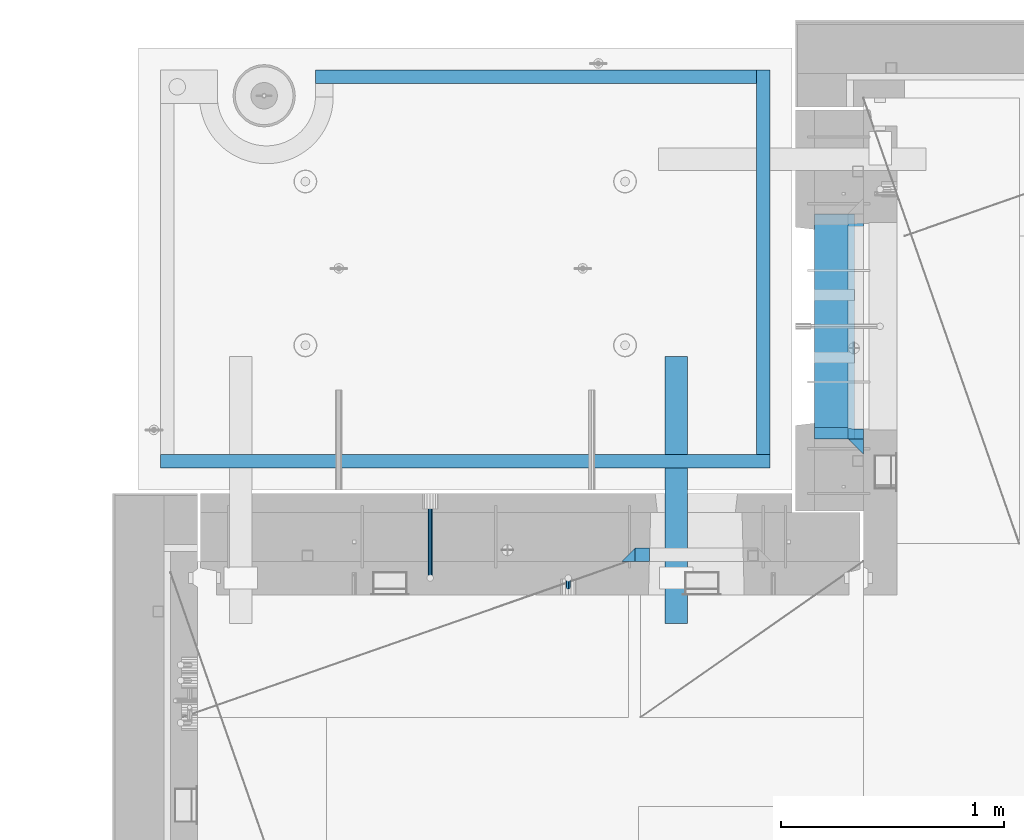
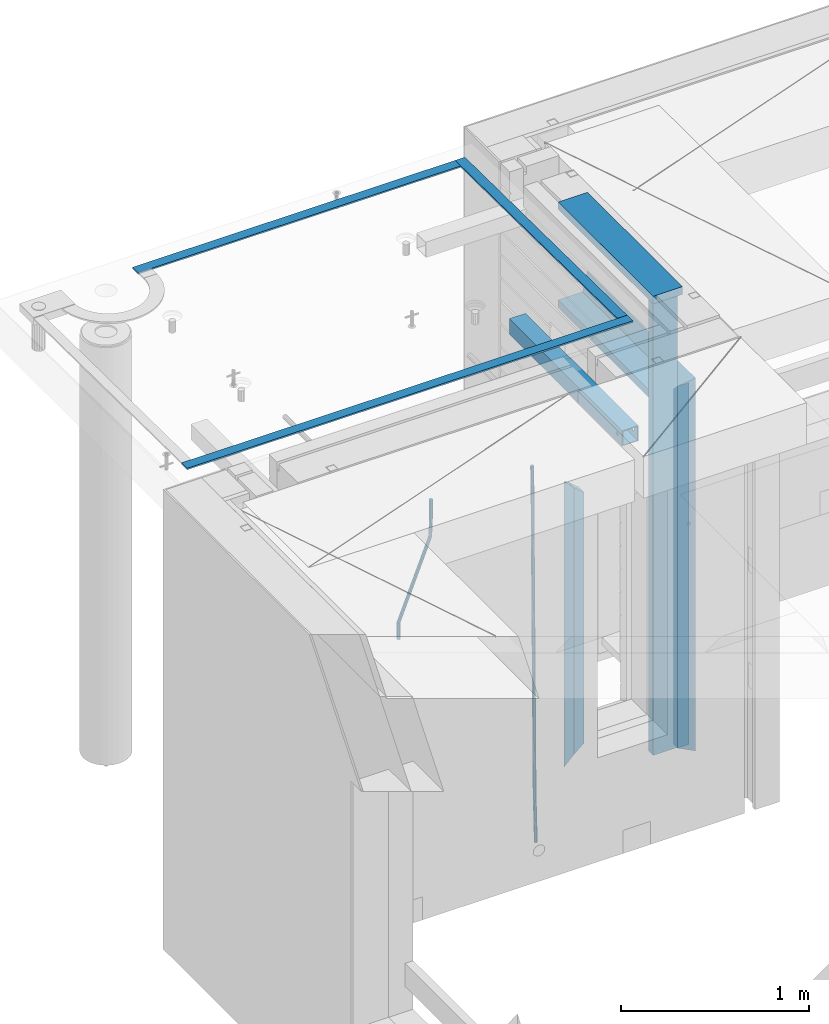
# One storey, part 116 of 350: 14 beams, 4 elements without a shape of their own.
"""IFC2X3 building model written with IfcOpenShell, lengths in millimetres."""

from ifc_helpers import new_model, si_unit, frame, origin_with_axes, place, context, subcontext, project, spatial, faceted_brep, material, type_object, element, aggregate, save


model = new_model("IFC2X3")

# Units and contexts
model_context = context("Model", 3, precision=1e-05, world=origin_with_axes())
body_context = subcontext(model_context, "Body", "Model", "MODEL_VIEW")
ifc_project = project(units=[si_unit("LENGTHUNIT", "METRE", prefix="MILLI"), si_unit("AREAUNIT", "SQUARE_METRE"), si_unit("VOLUMEUNIT", "CUBIC_METRE"), si_unit("MASSUNIT", "GRAM", prefix="KILO"), si_unit("TIMEUNIT", "SECOND"), si_unit("PLANEANGLEUNIT", "RADIAN"), si_unit("SOLIDANGLEUNIT", "STERADIAN"), si_unit("THERMODYNAMICTEMPERATUREUNIT", "DEGREE_CELSIUS"), si_unit("LUMINOUSINTENSITYUNIT", "LUMEN")], contexts=[model_context])

# Site, building, storey
site_placement = place(None, origin_with_axes())
site = spatial("IfcSite", under=ifc_project, at=site_placement, CompositionType="ELEMENT")
building_placement = place(site_placement, origin_with_axes())
building = spatial("IfcBuilding", under=site, at=building_placement, CompositionType="ELEMENT")
storey_placement = place(building_placement, origin_with_axes())
storey = spatial("IfcBuildingStorey", under=building, at=storey_placement, Name="2", CompositionType="ELEMENT", Elevation=0.0)

# Assembly, beams
assembly_1_placement = place(storey_placement, origin_with_axes())
assembly_1 = element("IfcElementAssembly", 1, at=assembly_1_placement, inside=storey, AssemblyPlace="NOTDEFINED", PredefinedType="REINFORCEMENT_UNIT")
ifc_material_1 = material(Name="CONCRETE/C25/30")
beam_type_1 = type_object("IfcBeamType", PredefinedType="NOTDEFINED")
beam_1_placement = place(assembly_1_placement, frame((10955.0, 22209.9998901814, 87140.0), z_axis=(0.0, 0.0, -1.0), x_axis=(0.0, -1.0, 0.0)))
beam_1 = element("IfcBeam", 2, at=beam_1_placement, type_object=beam_type_1, material=ifc_material_1, Name="SK", context=body_context, shape_type="Brep", body=[
    faceted_brep([(70.0000000000164, -35.0, 35.0), (70.0000000000164, 35.0, 35.0), (0.0, -35.0, -35.0), (1079.99961853027, -35.0, 35.0), (1079.99961853027, 35.0, 35.0), (1149.99961853027, -35.0, -35.0)], [[[0, 1, 2]], [[1, 0, 3, 4]], [[2, 1, 4, 5]], [[0, 2, 5, 3]], [[5, 4, 3]]]),
])
beam_2_placement = place(assembly_1_placement, frame((10955.0, 21095.0002716511, 87175.0), z_axis=(0.0, 1.0, 0.0), x_axis=(0.0, 0.0, -1.0)))
beam_2 = element("IfcBeam", 3, at=beam_2_placement, type_object=beam_type_1, material=ifc_material_1, Name="SK", context=body_context, shape_type="Brep", body=[
    faceted_brep([(2420.0, -35.0, 35.0), (2420.0, -35.0, -35.0), (2420.0, 35.0, 35.0), (70.0000000000164, -35.0, 35.0), (0.0, -35.0, -35.0), (70.0000000000164, 35.0, 35.0)], [[[0, 1, 2]], [[1, 0, 3, 4]], [[2, 1, 4, 5]], [[0, 2, 5, 3]], [[3, 5, 4]]]),
])
beam_type_2 = type_object("IfcBeamType", PredefinedType="NOTDEFINED")
beam_3_placement = place(assembly_1_placement, frame((10955.0, 21155.0002716511, 87105.0), z_axis=(0.0, 1.0, 0.0), x_axis=(0.0, 0.0, -1.0)))
beam_3 = element("IfcBeam", 4, at=beam_3_placement, type_object=beam_type_2, material=ifc_material_1, Name="SK", context=body_context, shape_type="Brep", body=[
    faceted_brep([(2350.0, -35.0, -25.0), (2350.0, 35.0, -25.0), (2350.0, 35.0, 20.6410256410309), (2350.0, -35.0, 18.8461538461561), (43.8461538461561, -35.0, 18.8461538461543), (0.0, -35.0, -25.0), (0.0, 35.0, -25.0), (45.6410256410309, 35.0, 20.6410256410254)], [[[0, 1, 2, 3]], [[0, 3, 4, 5]], [[1, 0, 5, 6]], [[2, 1, 6, 7]], [[3, 2, 7, 4]], [[7, 6, 5, 4]]]),
])
ifc_material_2 = material(Name="TIMBER")
beam_type_3 = type_object("IfcBeamType", Name="50X150", PredefinedType="NOTDEFINED")
beam_4_placement = place(assembly_1_placement, frame((10845.0, 22139.9998901814, 87080.0), z_axis=(0.0, 0.0, -1.0), x_axis=(0.0, -1.0, 0.0)))
beam_4 = element("IfcBeam", 5, at=beam_4_placement, type_object=beam_type_3, material=ifc_material_2, ObjectType="50X150", context=body_context, shape_type="Brep", body=[
    faceted_brep([(0.0, 75.0, -25.0), (1.81898940354586e-12, 75.0, 25.0), (1009.99961853027, 75.0, 25.0), (1009.99961853027, 75.0, -25.0), (1.81898940354586e-12, -75.0000000000009, 25.0), (1009.99961853027, -75.0, 25.0), (0.0, -75.0, -25.0), (1009.99961853027, -75.0, -25.0)], [[[0, 1, 2, 3]], [[1, 4, 5, 2]], [[4, 6, 7, 5]], [[6, 0, 3, 7]], [[5, 7, 3, 2]], [[6, 4, 1, 0]]]),
])
beam_5_placement = place(assembly_1_placement, frame((10845.0, 21155.0002716511, 87690.0), z_axis=(0.0, 1.0, 0.0), x_axis=(0.0, 0.0, -1.0)))
beam_5 = element("IfcBeam", 6, at=beam_5_placement, type_object=beam_type_3, material=ifc_material_2, ObjectType="50X150", context=body_context, shape_type="Brep", body=[
    faceted_brep([(0.0, 75.0, -25.0), (1.81898940354586e-12, 75.0, 25.0), (2930.0, 75.0, 25.0), (2930.0, 75.0, -25.0), (1.81898940354586e-12, -75.0000000000009, 25.0), (2930.0, -75.0, 25.0), (0.0, -75.0, -25.0), (2930.0, -75.0, -25.0)], [[[0, 1, 2, 3]], [[1, 4, 5, 2]], [[4, 6, 7, 5]], [[6, 0, 3, 7]], [[5, 7, 3, 2]], [[6, 4, 1, 0]]]),
])

assembly_2_placement = place(storey_placement, origin_with_axes())
assembly_2 = element("IfcElementAssembly", 7, at=assembly_2_placement, inside=storey, AssemblyPlace="NOTDEFINED", PredefinedType="REINFORCEMENT_UNIT")
ifc_material_3 = material()
beam_type_4 = type_object("IfcBeamType", Name="D20", PredefinedType="NOTDEFINED")
beam_6_placement = place(assembly_2_placement, frame((9665.0017200335, 20464.9951872276, 84990.0), z_axis=(-0.000205762999925498, 0.999642804629538, -0.0267249099901004), x_axis=(4.30000201928125e-08, 0.0267249099948059, 0.999642825806181)))
beam_6 = element("IfcBeam", 8, at=beam_6_placement, type_object=beam_type_4, material=ifc_material_3, Name="JM20", ObjectType="D20", context=body_context, shape_type="Brep", body=[
    faceted_brep([(0.0, -10.0, 0.0), (-4.19531716033816e-08, -7.07106781186667, -7.07106781187031), (60.4266690400545, -7.0710677960451, -7.07106780570757), (60.4266690441291, -9.99999998418934, 6.15546014159918e-09), (0.0, 0.0, -10.0), (60.426669036824, 1.58106558956206e-08, -9.99999999384454), (4.196772351861e-08, 7.07106781186303, -7.07106781186667), (60.4266690363438, 7.07106782768096, -7.07106780570757), (0.0, 10.0, 0.0), (60.4266690388904, 10.0000000158179, 6.15182216279209e-09), (4.196772351861e-08, 7.07106781185939, 7.07106781185939), (60.4266690429649, 7.07106782768096, 7.07106781802577), (0.0, 0.0, 10.0), (60.4266690461809, 1.58179318532348e-08, 10.0000000061555), (-4.19531716033816e-08, -7.07106781187031, 7.07106781185939), (60.4266690466611, -7.07106779605238, 7.07106781802213), (61.0378400410118, -7.07106779588503, -7.07106780564936), (60.991799419251, -9.99999998403655, 6.21366780251265e-09), (61.0569027789461, 1.5985278878361e-08, -9.99999999378269), (61.0378209396877, 7.07106782784831, -7.07106780564936), (60.9917724058905, 10.0000000159635, 6.21366780251265e-09), (60.9457317841297, 7.07106782781193, 7.0710678180767), (60.9266690461809, 1.59488990902901e-08, 10.0000000062028), (60.9457508854539, -7.07106779591413, 7.0710678180767), (61.6489592143771, -7.07106614513759, -7.06310863441468), (61.5568818710308, -9.9999984576425, 0.00735959856683621), (61.6870830769039, 1.71821739058942e-06, -9.99179257185824), (61.6489210170112, 7.07106947854481, -7.06310888312146), (61.556827851804, 10.0000015422847, 0.00735924683976918), (61.4647505084577, 7.07106922979438, 7.07782747982128), (61.4266266459163, 1.36643211590126e-06, 10.0065114172685), (61.464788705809, -7.07106639389531, 7.07782772852806), (176.543135720174, -7.07075579406956, -5.56673531796696), (176.451058376813, -9.99968810657447, 1.50373291501455), (176.581259582701, 0.000312069292704109, -8.49541925541052), (176.543097522794, 7.07137982961285, -5.56673556667374), (176.451004357587, 10.00031189336, 1.50373256329476), (176.35892701424, 7.07137958085514, 8.57420079627263), (176.320803151699, 0.000311717507429421, 11.5028847337162), (176.358965211621, -7.07075604281999, 8.57420104497578), (177.098753836006, -7.07075429323595, -5.55949898843028), (176.98362511232, -9.99968666800123, 1.510669025065), (177.146421932586, 0.000313595905026887, -8.48805862247536), (177.098706077581, 7.07138133041735, -5.55949936166144), (176.983557571715, 10.0003133318824, 1.51066849724157), (176.868428848029, 7.07138095712435, 8.58083651073321), (176.820760751449, 0.000313067976094317, 11.5093961447819), (176.868476606425, -7.07075466652896, 8.58083688396073), (177.654312950661, -7.07075204110879, -5.54863964998367), (177.516135294456, -9.99968450931192, 1.52107783331303), (177.711524267797, 0.000315886711177882, -8.47701274570863), (177.654255632195, 7.07138358250813, -5.54864021007961), (177.516054233929, 10.0003154905207, 1.5210770412159), (177.377876577739, 7.0713830223176, 8.59079452451624), (177.320665260588, 0.000315094497636892, 11.5191676202448), (177.377933896176, -7.07075260129932, 8.59079508461218), (299.436796249574, -7.07025836271714, -3.1681962331204), (299.298618593355, -9.99919083092027, 3.90152125031091), (299.494007566798, 0.000809565110102994, -6.09656932889993), (299.436738931283, 7.07187726089978, -3.16819679320906), (299.298537533061, 10.0008091689197, 3.90152045822106), (299.160359876842, 7.07187670072017, 10.9712379416487), (299.103148559603, 0.000808772889286047, 13.8996110374392), (299.160417195119, -7.07025892290039, 10.9712385017483), (299.98743051647, -7.07025613056248, -3.15743315966392), (299.971788958996, -9.99918809853989, 3.91467979818117), (299.993912075952, 0.000811591617093654, -6.08679785393178), (299.987423933868, 7.07187949325817, -3.1574327280432), (299.971753863239, 10.0008119014747, 3.91467990454839), (299.95611230444, 7.07187992653053, 10.9867922621015), (299.949630744944, 0.000812204350950196, 13.9161569563694), (299.956118887014, -7.07025569729012, 10.9867918304735), (300.538107039494, -7.07025785017686, -3.16575821840888), (300.644985195438, -9.99919020432935, 3.90450175465594), (300.493854948218, 0.000810030429420294, -6.09435592770024), (300.538151196495, 7.071877773491, -3.16575855385963), (300.645047642858, 10.0008097955724, 3.90450128024895), (300.751925798773, 7.07187744142357, 10.9747612533101), (300.796177890064, 0.000809560813650023, 13.9033589625978), (300.751881641787, -7.07025818224065, 10.9747615887682), (2293.36490490142, -7.07648090940347, -33.2930642912361), (2293.47178305736, -10.0054132635523, -26.2228043181785), (2293.32065281013, -0.00541302880083094, -36.2216620005347), (2293.36494905842, 7.06565471425711, -33.2930646266868), (2293.47184550477, 9.99458673634581, -26.2228047925819), (2293.57872366071, 7.06565438219332, -19.1525448195243), (2293.62297575199, -0.00541349841296324, -16.2239471102366), (2293.57867950371, -7.0764812414709, -19.1525444840736), (2294.0658245362, -7.07648309818615, -33.3036607065333), (2294.05312277409, -10.0054150789219, -26.2315929392535), (2294.10928714235, -0.00541549149056664, -36.2335844756526), (2294.15805078732, 7.06565223761572, -33.3050546393533), (2294.18355038921, 9.99458451388637, -26.2335642579346), (2294.17084862708, 7.06565253314329, -19.1614964906439), (2294.12738602093, -0.00541507354500936, -16.2315727215355), (2294.07862237596, -7.07648280265857, -19.1601025578348), (2294.76670261032, -7.08562269121467, -33.294332712383), (2294.63442802057, -10.0129954178956, -26.2238563411993), (2294.89787471293, -0.0156988342423574, -36.2230891548279), (2294.95110548967, 7.05531064255774, -33.2944998654275), (2294.89521307347, 9.98530428734011, -26.2240927312887), (2294.76293848372, 7.0579315606592, -19.1536163601049), (2294.63176638114, -0.0119922963167483, -16.2248599176673), (2294.57853560438, -7.08300177311321, -19.1534492070678), (2316.52657204497, -7.36937582653991, -33.0047303660212), (2316.39429745522, -10.2967485532172, -25.9342539948302), (2316.65774414754, -0.299451969567599, -35.9334868084661), (2316.7109749243, 6.7715575072325, -33.0048975190657), (2316.65508250811, 9.70155115201487, -25.9344903849269), (2316.52280791836, 6.7741784253376, -18.8640140137468), (2316.39163581574, -0.295745431634714, -15.9352575713092), (2316.33840503903, -7.36675490843481, -18.863846860706), (2317.16202064224, -7.37766220584308, -32.9962731735213), (2317.05438744847, -10.3053562613532, -25.9254688497131), (2317.23607125619, -0.306993473008333, -35.925789846493), (2317.23316144495, 6.76474808850253, -32.9979477328052), (2317.15499573652, 9.6950321815566, -25.9278370341635), (2317.04736254275, 6.7673381260538, -18.8570327103698), (2316.97331192881, -0.303330606784584, -15.9275160373909), (2316.97622174003, -7.37507216829545, -18.8553581510787), (2317.79752306276, -7.37578610372293, -32.9880110666527), (2317.71453320107, -10.3033876998124, -25.9168792378296), (2317.81444760226, -0.305295583297266, -35.918287695793), (2317.75539265381, 6.76628640723357, -32.9911928173897), (2317.65495180529, 9.69652304524061, -25.9213789128698), (2317.5719619436, 6.76892144914746, -18.8502470840467), (2317.55503740412, -0.301569071270933, -15.9199704549137), (2317.61409235255, -7.3731510618054, -18.847065333317), (2417.8183084176, -7.07752398473531, -31.6906369377139), (2417.73531855589, -10.0051255808248, -24.6195051088798), (2417.83523295709, -0.007033464313281, -34.6209135668432), (2417.77617800863, 7.06454852621755, -31.6938186884508), (2417.67573716014, 9.99478516423187, -24.6240047839383), (2417.59274729842, 7.06718356813872, -17.5528729551006), (2417.57582275895, -0.00330695228694822, -14.6225963259749), (2417.6348777074, -7.07488894281778, -17.5496912043673)], [[[0, 1, 2, 3]], [[1, 4, 5, 2]], [[4, 6, 7, 5]], [[6, 8, 9, 7]], [[8, 10, 11, 9]], [[10, 12, 13, 11]], [[12, 14, 15, 13]], [[14, 0, 3, 15]], [[14, 12, 10, 8, 6, 4, 1, 0]], [[3, 2, 16, 17]], [[2, 5, 18, 16]], [[5, 7, 19, 18]], [[7, 9, 20, 19]], [[9, 11, 21, 20]], [[11, 13, 22, 21]], [[13, 15, 23, 22]], [[15, 3, 17, 23]], [[17, 16, 24, 25]], [[16, 18, 26, 24]], [[18, 19, 27, 26]], [[19, 20, 28, 27]], [[20, 21, 29, 28]], [[21, 22, 30, 29]], [[22, 23, 31, 30]], [[23, 17, 25, 31]], [[25, 24, 32, 33]], [[24, 26, 34, 32]], [[26, 27, 35, 34]], [[27, 28, 36, 35]], [[28, 29, 37, 36]], [[29, 30, 38, 37]], [[30, 31, 39, 38]], [[31, 25, 33, 39]], [[33, 32, 40, 41]], [[32, 34, 42, 40]], [[34, 35, 43, 42]], [[35, 36, 44, 43]], [[36, 37, 45, 44]], [[37, 38, 46, 45]], [[38, 39, 47, 46]], [[39, 33, 41, 47]], [[41, 40, 48, 49]], [[40, 42, 50, 48]], [[42, 43, 51, 50]], [[43, 44, 52, 51]], [[44, 45, 53, 52]], [[45, 46, 54, 53]], [[46, 47, 55, 54]], [[47, 41, 49, 55]], [[49, 48, 56, 57]], [[48, 50, 58, 56]], [[50, 51, 59, 58]], [[51, 52, 60, 59]], [[52, 53, 61, 60]], [[53, 54, 62, 61]], [[54, 55, 63, 62]], [[55, 49, 57, 63]], [[57, 56, 64, 65]], [[56, 58, 66, 64]], [[58, 59, 67, 66]], [[59, 60, 68, 67]], [[60, 61, 69, 68]], [[61, 62, 70, 69]], [[62, 63, 71, 70]], [[63, 57, 65, 71]], [[65, 64, 72, 73]], [[64, 66, 74, 72]], [[66, 67, 75, 74]], [[67, 68, 76, 75]], [[68, 69, 77, 76]], [[69, 70, 78, 77]], [[70, 71, 79, 78]], [[71, 65, 73, 79]], [[73, 72, 80, 81]], [[72, 74, 82, 80]], [[74, 75, 83, 82]], [[75, 76, 84, 83]], [[76, 77, 85, 84]], [[77, 78, 86, 85]], [[78, 79, 87, 86]], [[79, 73, 81, 87]], [[81, 80, 88, 89]], [[80, 82, 90, 88]], [[82, 83, 91, 90]], [[83, 84, 92, 91]], [[84, 85, 93, 92]], [[85, 86, 94, 93]], [[86, 87, 95, 94]], [[87, 81, 89, 95]], [[89, 88, 96, 97]], [[88, 90, 98, 96]], [[90, 91, 99, 98]], [[91, 92, 100, 99]], [[92, 93, 101, 100]], [[93, 94, 102, 101]], [[94, 95, 103, 102]], [[95, 89, 97, 103]], [[97, 96, 104, 105]], [[96, 98, 106, 104]], [[98, 99, 107, 106]], [[99, 100, 108, 107]], [[100, 101, 109, 108]], [[101, 102, 110, 109]], [[102, 103, 111, 110]], [[103, 97, 105, 111]], [[105, 104, 112, 113]], [[104, 106, 114, 112]], [[106, 107, 115, 114]], [[107, 108, 116, 115]], [[108, 109, 117, 116]], [[109, 110, 118, 117]], [[110, 111, 119, 118]], [[111, 105, 113, 119]], [[113, 112, 120, 121]], [[112, 114, 122, 120]], [[114, 115, 123, 122]], [[115, 116, 124, 123]], [[116, 117, 125, 124]], [[117, 118, 126, 125]], [[118, 119, 127, 126]], [[119, 113, 121, 127]], [[121, 120, 128, 129]], [[120, 122, 130, 128]], [[122, 123, 131, 130]], [[123, 124, 132, 131]], [[124, 125, 133, 132]], [[125, 126, 134, 133]], [[126, 127, 135, 134]], [[127, 121, 129, 135]], [[130, 131, 132, 133, 134, 135, 129, 128]]]),
])
beam_7_placement = place(assembly_2_placement, frame((9044.99633337453, 20504.9951872346, 87407.5), z_axis=(0.000415599999849905, 0.999999913638203, 4.76000000899737e-07), x_axis=(0.0, 0.0, -1.0)))
beam_7 = element("IfcBeam", 9, at=beam_7_placement, type_object=beam_type_4, material=ifc_material_3, Name="JM20", ObjectType="D20", context=body_context, shape_type="Brep", body=[
    faceted_brep([(-0.00060564729210455, -9.99999998165731, 0.0), (-0.000428079845733009, -7.07106779890455, -7.07106781186667), (119.575515501536, -7.07830994756296, -7.07106481604933), (119.575337932896, -10.0072421307195, -3.43332612828817e-06), (0.0, 0.0, -10.0), (119.575943836026, -0.00724214867295814, -9.99999700418266), (0.00042843479604926, 7.07106779888636, -7.07106781186303), (119.57637202373, 7.06382565022977, -7.07106481604933), (0.00060564729210455, 9.99999998166459, 3.63797880709171e-12), (119.576549238118, 9.99275783300072, 2.99581552098971e-06), (0.000428079845733009, 7.07106779890819, 7.07106781186667), (119.576371669405, 7.06382565024978, 7.07107080768037), (0.0, 0.0, 10.0), (119.57594333493, -0.00724214864203532, 10.0000029958155), (-0.000428434810601175, -7.07106779888272, 7.07106781186667), (119.575515147211, -7.07830994754295, 7.07107080768037), (123.00654325854, -7.07836650239551, -6.96786008391246), (122.581588830741, -10.007295666459, 0.0904344953341933), (123.182419066041, -0.00729994480025198, -9.89151006310021), (123.006190977103, 7.06376911688858, -6.96788735351402), (122.581091016109, 9.99270432680532, 0.0903895128230943), (122.156136974867, 7.06377516229986, 7.14867767459873), (121.980261167351, -0.00729139528993983, 10.0723276537792), (122.156489256289, -7.07836045697513, 7.14870494419847), (237.077376207715, -7.07551629289992, -0.0988779924864502), (236.652422053201, -10.0044409119728, 6.95941204931296), (237.253252288647, -0.0044516184279928, -3.02253250974718), (237.077024472936, 7.06661932641327, -0.0989143382521434), (236.651924624995, 9.99555908263574, 6.95936064834314), (236.226970470365, 7.06663446442326, 14.0176506898479), (236.051094389448, -0.0044302100486675, 16.9413052071086), (236.227322205144, -7.07550115488812, 14.0176870356117), (256.715938387759, -7.07353516174771, 4.66794781703175), (253.858321224223, -10.0027051854922, 11.1357628166734), (257.898622435067, -0.00236892073007766, 1.98867362452802), (256.713573090979, 7.0686002544353, 4.66742272414376), (253.85497618909, 9.99729452004976, 11.1350202234971), (250.997359025234, 7.06812449537756, 17.6028352234607), (249.814674977912, -0.00304174564189452, 20.2821094159572), (250.999724322028, -7.07401092080545, 17.6033603163596), (1009.84102825288, -6.93521658215468, 337.477148757798), (1006.98341108896, -9.86438660663771, 343.944963757851), (1011.02371230032, 0.135949658781101, 334.7978745651), (1009.83866295629, 7.20691883402651, 337.476623664521), (1006.98006605446, 10.1356130998429, 343.944221163818), (1004.12244889054, 7.2064430753635, 350.412036163872), (1002.9397648431, 0.135276834424076, 353.091310356571), (1004.12481418712, -6.93569234081951, 350.412561257146), (1010.86335274603, -6.9350288225487, 337.928918327354), (1009.37086865908, -9.86394812736762, 344.999991477531), (1011.48104818776, 0.136033652863262, 334.999973251377), (1010.86211737194, 7.20710680115553, 337.928892551665), (1009.36912157628, 10.1360518725905, 344.9999550252), (1007.87663748935, 7.2071325677698, 352.071028175378), (1007.2589420476, 0.13607009235966, 354.999973251352), (1007.87787286344, -6.93500305593261, 352.071053951067), (1011.98104820926, -6.93502881915083, 337.92891832735), (1011.98104821818, -9.86394811943501, 344.999991477524), (1011.98104818776, 0.136033654382118, 334.999973251375), (1011.98104816627, 7.20710680455704, 337.928892551661), (1011.98104815738, 10.1360518805304, 344.999955025194), (1011.98104816629, 7.20713258024625, 352.071028175369), (1011.98104818778, 0.136070106711486, 354.999973251342), (1011.98104820927, -6.9350030434598, 352.071053951058), (1117.50000002154, -6.93502849844299, 337.928918327156), (1117.50000003044, -9.86394779872717, 344.999991477331), (1117.50000000004, 0.136033975091777, 334.999973251181), (1117.49999997855, 7.20710712526488, 337.928892551467), (1117.49999996964, 10.1360522012383, 344.999955025), (1117.49999997857, 7.20713290095409, 352.071028175174), (1117.50000000006, 0.136070427419327, 354.999973251148), (1117.50000002155, -6.93500272275196, 352.071053950864)], [[[0, 1, 2, 3]], [[1, 4, 5, 2]], [[4, 6, 7, 5]], [[6, 8, 9, 7]], [[8, 10, 11, 9]], [[10, 12, 13, 11]], [[12, 14, 15, 13]], [[14, 0, 3, 15]], [[14, 12, 10, 8, 6, 4, 1, 0]], [[3, 2, 16, 17]], [[2, 5, 18, 16]], [[5, 7, 19, 18]], [[7, 9, 20, 19]], [[9, 11, 21, 20]], [[11, 13, 22, 21]], [[13, 15, 23, 22]], [[15, 3, 17, 23]], [[17, 16, 24, 25]], [[16, 18, 26, 24]], [[18, 19, 27, 26]], [[19, 20, 28, 27]], [[20, 21, 29, 28]], [[21, 22, 30, 29]], [[22, 23, 31, 30]], [[23, 17, 25, 31]], [[25, 24, 32, 33]], [[24, 26, 34, 32]], [[26, 27, 35, 34]], [[27, 28, 36, 35]], [[28, 29, 37, 36]], [[29, 30, 38, 37]], [[30, 31, 39, 38]], [[31, 25, 33, 39]], [[33, 32, 40, 41]], [[32, 34, 42, 40]], [[34, 35, 43, 42]], [[35, 36, 44, 43]], [[36, 37, 45, 44]], [[37, 38, 46, 45]], [[38, 39, 47, 46]], [[39, 33, 41, 47]], [[41, 40, 48, 49]], [[40, 42, 50, 48]], [[42, 43, 51, 50]], [[43, 44, 52, 51]], [[44, 45, 53, 52]], [[45, 46, 54, 53]], [[46, 47, 55, 54]], [[47, 41, 49, 55]], [[49, 48, 56, 57]], [[48, 50, 58, 56]], [[50, 51, 59, 58]], [[51, 52, 60, 59]], [[52, 53, 61, 60]], [[53, 54, 62, 61]], [[54, 55, 63, 62]], [[55, 49, 57, 63]], [[57, 56, 64, 65]], [[56, 58, 66, 64]], [[58, 59, 67, 66]], [[59, 60, 68, 67]], [[60, 61, 69, 68]], [[61, 62, 70, 69]], [[62, 63, 71, 70]], [[63, 57, 65, 71]], [[66, 67, 68, 69, 70, 71, 65, 64]]]),
])

# Assemblies, beams
assembly_3_placement = place(storey_placement, origin_with_axes())
assembly_3 = element("IfcElementAssembly", 10, at=assembly_3_placement, inside=storey, AssemblyPlace="NOTDEFINED", PredefinedType="REINFORCEMENT_UNIT")
assembly_4_placement = place(assembly_3_placement, origin_with_axes())
assembly_4 = element("IfcElementAssembly", 11, at=assembly_4_placement, AssemblyPlace="NOTDEFINED", PredefinedType="NOTDEFINED")
ifc_material_4 = material(Name="Undefined/350")
beam_type_5 = type_object("IfcBeamType", Name="100X100X5", PredefinedType="NOTDEFINED")
beam_8_placement = place(assembly_4_placement, frame((10150.0001432011, 21500.0034426031, 87555.0), z_axis=(0.0, 0.0, 1.0), x_axis=(-2.2242999997242e-05, -0.999999999752625, 0.0)))
beam_8 = element("IfcBeam", 12, at=beam_8_placement, type_object=beam_type_5, material=ifc_material_4, ObjectType="100X100X5", context=body_context, shape_type="Brep", body=[
    faceted_brep([(1143.75108023171, 44.9999999999982, -10.8253175473074), (1143.75107855316, 50.0255964196231, -10.8253175473074), (1139.17576100585, 50.0255948914664, -6.25), (1139.1757626844, 44.9999999999982, -6.25), (1150.00108023171, 44.9999999999982, -12.5), (1150.00107855316, 50.0255985071226, -12.5), (1156.2510802317, 44.9999999999982, -10.8253175473074), (1156.25107855315, 50.0256005946221, -10.8253175473074), (1160.82639777901, 44.9999999999982, -6.25), (1160.82639610046, 50.0256021227788, -6.25), (1162.50108023171, 44.9999999999982, 0.0), (1162.50107855316, 50.0256026821226, 0.0), (1160.82639777901, 44.9999999999982, 6.25), (1160.82639610046, 50.0256021227788, 6.25), (1156.2510802317, 44.9999999999982, 10.8253175473074), (1156.25107855315, 50.0256005946221, 10.8253175473074), (1150.00108023171, 44.9999999999982, 12.5), (1150.00107855316, 50.0255985071226, 12.5), (1143.75108023171, 44.9999999999982, 10.8253175473074), (1143.75107855316, 50.0255964196231, 10.8253175473074), (1139.1757626844, 44.9999999999982, 6.25), (1139.17576100585, 50.0255948914664, 6.25), (1137.5010802317, 44.9999999999982, 0.0), (1137.50107855316, 50.0255943321226, 0.0), (1143.75111195316, -49.9744035792783, -10.8253175473074), (1143.75111029171, -44.9999999999991, -10.8253175473074), (1139.1757927444, -44.9999999999991, -6.25), (1139.17579440585, -49.9744051074349, -6.25), (1150.00111195316, -49.9744014917787, -12.5), (1150.00111029171, -44.9999999999991, -12.5), (1156.25111195316, -49.9743994042774, -10.8253175473074), (1156.25111029171, -44.9999999999991, -10.8253175473074), (1160.82642950046, -49.9743978761207, -6.25), (1160.82642783901, -44.9999999999991, -6.25), (1162.50111195316, -49.9743973167779, 0.0), (1162.50111029171, -44.9999999999991, 0.0), (1160.82642950046, -49.9743978761207, 6.25), (1160.82642783901, -44.9999999999991, 6.25), (1156.25111195316, -49.9743994042774, 10.8253175473074), (1156.25111029171, -44.9999999999991, 10.8253175473074), (1150.00111195316, -49.9744014917787, 12.5), (1150.00111029171, -44.9999999999991, 12.5), (1143.75111195316, -49.9744035792783, 10.8253175473074), (1143.75111029171, -44.9999999999991, 10.8253175473074), (1139.17579440585, -49.9744051074349, 6.25), (1139.1757927444, -44.9999999999991, 6.25), (1137.50111195316, -49.9744056667778, 0.0), (1137.50111029171, -44.9999999999991, 0.0), (1.81898940354586e-12, -50.0000000000009, -50.0), (1.81898940354586e-12, 49.9999999999991, -50.0), (1200.00449189278, 49.9999999999982, -50.0), (1200.00449189278, -50.0000000000009, -50.0), (1.81898940354586e-12, 49.9999999999991, 50.0), (1.81898940354586e-12, -50.0000000000009, 50.0), (1200.00449189278, -50.0000000000009, 50.0), (1200.00449189278, 49.9999999999982, 50.0), (0.0, 44.9999999999991, 45.0), (1.81898940354586e-12, -45.0000000000009, 45.0), (1.81898940354586e-12, -45.0000000000009, -45.0), (0.0, 44.9999999999991, -45.0), (1200.00449189278, 44.9999999999982, -45.0), (1200.00449189278, 44.9999999999982, 45.0), (1200.00449189278, -45.0000000000009, 45.0), (1200.00449189278, -45.0000000000009, -45.0)], [[[0, 1, 2, 3]], [[4, 5, 1, 0]], [[6, 7, 5, 4]], [[8, 9, 7, 6]], [[10, 11, 9, 8]], [[12, 13, 11, 10]], [[14, 15, 13, 12]], [[16, 17, 15, 14]], [[18, 19, 17, 16]], [[20, 21, 19, 18]], [[22, 23, 21, 20]], [[3, 2, 23, 22]], [[24, 25, 26, 27]], [[28, 29, 25, 24]], [[30, 31, 29, 28]], [[32, 33, 31, 30]], [[34, 35, 33, 32]], [[36, 37, 35, 34]], [[38, 39, 37, 36]], [[40, 41, 39, 38]], [[42, 43, 41, 40]], [[44, 45, 43, 42]], [[46, 47, 45, 44]], [[27, 26, 47, 46]], [[48, 49, 50, 51]], [[52, 53, 54, 55]], [[49, 52, 55, 50], [15, 17, 19, 21, 23, 2, 1, 5, 7, 9, 11, 13]], [[48, 53, 52, 49], [56, 57, 58, 59]], [[56, 59, 60, 61], [6, 4, 0, 3, 22, 20, 18, 16, 14, 12, 10, 8]], [[57, 56, 61, 62]], [[58, 57, 62, 63], [39, 41, 43, 45, 47, 26, 25, 29, 31, 33, 35, 37]], [[59, 58, 63, 60]], [[54, 51, 50, 55], [62, 61, 60, 63]], [[53, 48, 51, 54], [30, 28, 24, 27, 46, 44, 42, 40, 38, 36, 34, 32]]]),
])
aggregate(assembly_4, [beam_8])
ifc_material_5 = material(Name="CONCRETE/Concrete_Undefined")
beam_type_6 = type_object("IfcBeamType", PredefinedType="NOTDEFINED")
beam_9_placement = place(assembly_3_placement, frame((8529.99466999203, 22755.2837502302, 87704.830444231), z_axis=(-8.94119999996021e-05, 2.00000067707701e-09, 0.999999996002747), x_axis=(0.999999995749149, -2.25209999937896e-05, 8.94119999812374e-05)))
beam_9 = element("IfcBeam", 13, at=beam_9_placement, type_object=beam_type_6, material=ifc_material_5, context=body_context, shape_type="Brep", body=[
    faceted_brep([(2.5465851649642e-11, 29.9999999999982, -4.99999999998545), (-2.91038304567337e-11, 29.9999999999982, 5.0), (1980.00575712919, 30.0, 5.0), (1980.00575712919, 30.0, -5.0), (-2.5465851649642e-11, -30.0000000000018, 5.0), (1980.00575712919, -30.0, 5.0), (2.72848410531878e-11, -30.0000000000018, -4.99999999998545), (1980.00575712919, -30.0, -5.00000000001455)], [[[0, 1, 2, 3]], [[1, 4, 5, 2]], [[4, 6, 7, 5]], [[6, 0, 3, 7]], [[5, 7, 3, 2]], [[6, 4, 1, 0]]]),
])
beam_10_placement = place(assembly_3_placement, frame((10540.0586106742, 21059.9845873458, 87725.6637899649), z_axis=(-4.06999999693443e-07, 0.0121707750045615, 0.999925933374879), x_axis=(-3.34759999933477e-05, 0.999925932814682, -0.0121707749977451)))
beam_10 = element("IfcBeam", 14, at=beam_10_placement, type_object=beam_type_6, material=ifc_material_5, context=body_context, shape_type="Brep", body=[
    faceted_brep([(2.5465851649642e-11, 29.9999999999982, -4.99999999998545), (-2.91038304567337e-11, 29.9999999999982, 5.0), (1725.44357525616, 30.0000000000036, 5.00000000001455), (1725.4435752563, 30.0, -4.9999999999709), (-2.5465851649642e-11, -30.0000000000018, 5.0), (1725.44357525616, -29.9999999999964, 5.0000000000291), (2.72848410531878e-11, -30.0000000000018, -4.99999999998545), (1725.4435752563, -30.0, -4.99999999998545)], [[[0, 1, 2, 3]], [[1, 4, 5, 2]], [[4, 6, 7, 5]], [[6, 0, 3, 7]], [[5, 7, 3, 2]], [[6, 4, 1, 0]]]),
])
beam_11_placement = place(assembly_3_placement, frame((7834.99819277187, 21029.998155674, 87725.2788443216), z_axis=(-0.000140627000015522, 4.00000135459113e-09, 0.999999990112023), x_axis=(0.999999989763253, -2.64109999939869e-05, 0.000140626999967189)))
beam_11 = element("IfcBeam", 15, at=beam_11_placement, type_object=beam_type_6, material=ifc_material_5, context=body_context, shape_type="Brep", body=[
    faceted_brep([(2.5465851649642e-11, 29.9999999999982, -4.99999999998545), (-2.91038304567337e-11, 29.9999999999982, 5.0), (2735.00002544224, 30.0, 5.0), (2735.00002544224, 30.0, -5.0), (-2.5465851649642e-11, -30.0000000000018, 5.0), (2735.00002544224, -29.9999999999964, 5.0), (2.72848410531878e-11, -30.0000000000018, -4.99999999998545), (2735.00002544224, -29.9999999999964, -5.0)], [[[0, 1, 2, 3]], [[1, 4, 5, 2]], [[4, 6, 7, 5]], [[6, 0, 3, 7]], [[5, 7, 3, 2]], [[6, 4, 1, 0]]]),
])
aggregate(assembly_3, [assembly_4, beam_9, beam_10, beam_11])

# Beam
beam_type_7 = type_object("IfcBeamType", PredefinedType="NOTDEFINED")
beam_12_placement = place(assembly_2_placement, frame((9934.99871015549, 20609.9951872276, 87175.0), z_axis=(1.0, 0.0, 0.0), x_axis=(0.0, 0.0, -1.0)))
beam_12 = element("IfcBeam", 16, at=beam_12_placement, type_object=beam_type_7, material=ifc_material_1, Name="SK", context=body_context, shape_type="Brep", body=[
    faceted_brep([(60.0000000000073, 30.0, 30.0), (0.0, -30.0, -30.0), (60.0000000000073, -30.0, 30.0), (1795.00000000001, 30.0, 30.0), (1855.0, -30.0, -30.0), (1795.00000000001, -30.0, 30.0)], [[[0, 1, 2]], [[3, 4, 1, 0]], [[4, 5, 2, 1]], [[5, 3, 0, 2]], [[5, 4, 3]]]),
])

beam_type_8 = type_object("IfcBeamType", PredefinedType="NOTDEFINED")
beam_13_placement = place(assembly_2_placement, frame((9999.99871015549, 20609.9951872276, 87115.0), z_axis=(1.0, 0.0, 0.0), x_axis=(0.0, 0.0, -1.0)))
beam_13 = element("IfcBeam", 17, at=beam_13_placement, type_object=beam_type_8, material=ifc_material_1, Name="SK", context=body_context, shape_type="Brep", body=[
    faceted_brep([(0.0, -30.0, -35.0), (54.9034748914273, -30.0, 29.0540540540533), (56.2934362811066, 30.0, 30.6756756756768), (0.0, 30.0, -35.0), (1678.70656371891, 30.0, 30.6756756756768), (1735.0, 30.0, -35.0), (1735.0, -30.0, -35.0), (1680.09652510857, -30.0, 29.0540540540533)], [[[0, 1, 2, 3]], [[3, 2, 4, 5]], [[5, 6, 0, 3]], [[1, 0, 6, 7]], [[2, 1, 7, 4]], [[6, 5, 4, 7]]]),
])

aggregate(assembly_2, [beam_6, beam_7, beam_12, beam_13])

beam_type_9 = type_object("IfcBeamType", PredefinedType="NOTDEFINED")
beam_14_placement = place(assembly_1_placement, frame((10860.0, 21129.9999618525, 87715.0), z_axis=(0.0, 0.0, 1.0), x_axis=(0.0, 1.0, 0.0)))
beam_14 = element("IfcBeam", 18, at=beam_14_placement, type_object=beam_type_9, material=ifc_material_2, context=body_context, shape_type="Brep", body=[
    faceted_brep([(0.0, 90.0, -25.0), (0.0, 90.0, 25.0), (1009.99983857082, 90.0, 25.0), (1009.99983857082, 90.0, -25.0), (0.0, -90.0, 25.0), (1009.99983857082, -90.0, 25.0), (0.0, -90.0, -25.0), (1009.99983857082, -90.0, -25.0)], [[[0, 1, 2, 3]], [[1, 4, 5, 2]], [[4, 6, 7, 5]], [[6, 0, 3, 7]], [[5, 7, 3, 2]], [[6, 4, 1, 0]]]),
])

aggregate(assembly_1, [beam_1, beam_2, beam_3, beam_4, beam_5, beam_14])

save(model, "model.ifc")
